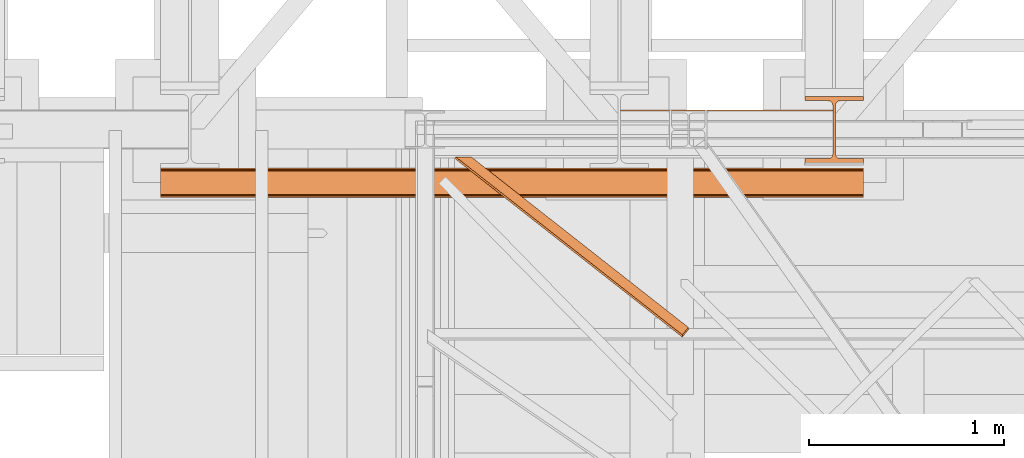
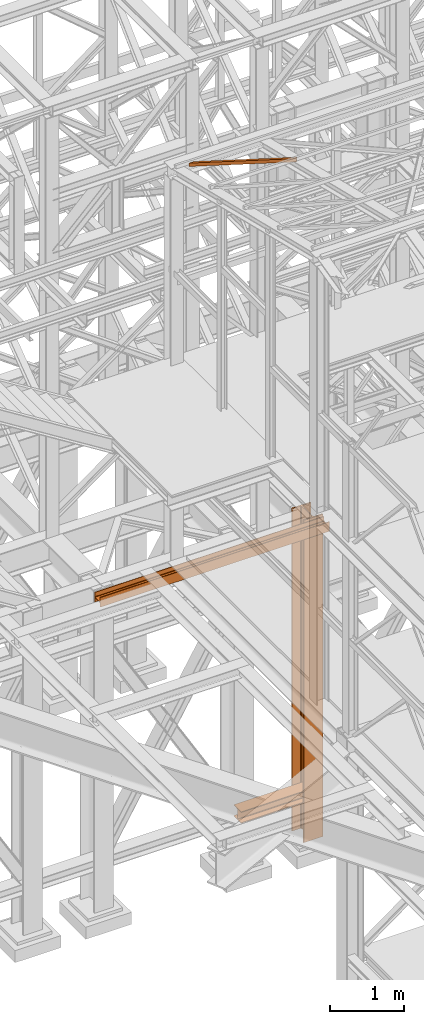
# One storey, part 38 of 208: 4 proxies.
"""IFC2X3 building model written with IfcOpenShell, lengths in millimetres."""

from ifc_helpers import new_model, entity, si_unit, converted_unit, frame, origin, origin_with_axes, place, context, subcontext, project, spatial, faceted_brep, material, element, save


model = new_model("IFC2X3")

# Units and contexts
model_context = context("Model", 3, precision=1e-05, world=origin())
plan_context = context("Plan", 3, precision=1e-05, world=origin())
body_context = subcontext(model_context, "Body", "Model", "MODEL_VIEW")
ifc_project = project(units=[si_unit("LENGTHUNIT", "METRE", prefix="MILLI"), converted_unit("PLANEANGLEUNIT", "DEGREE", entity("IfcPlaneAngleMeasure", 0.0174532925199433), si_unit("PLANEANGLEUNIT", "RADIAN"), dimensions=[0, 0, 0, 0, 0, 0, 0]), si_unit("AREAUNIT", "SQUARE_METRE"), si_unit("VOLUMEUNIT", "CUBIC_METRE")], contexts=[model_context, plan_context])

# Building, storey
building_placement = place(None, origin())
building = spatial("IfcBuilding", under=ifc_project, at=building_placement, CompositionType="COMPLEX")
storey_placement = place(building_placement, origin_with_axes())
storey = spatial("IfcBuildingStorey", under=building, at=storey_placement, Name="Geschoss", CompositionType="ELEMENT")

# Proxies
ifc_material = material(Name="35/80cm")
proxy_1_placement = place(storey_placement, frame((3143.254962568202, -17432.57439531565, -65.01000000000022), z_axis=(0.0, 0.0, 1.0), x_axis=(1.0, 0.0, 0.0)))
element("IfcBuildingElementProxy", 1, at=proxy_1_placement, inside=storey, material=ifc_material, context=body_context, shape_type="Brep", body=[
    faceted_brep([(300.0100119209292, 0.00999999999839929, 0.01000000000027512), (300.0100119209292, 21.51000631809075, 0.01000000000027512), (183.0100057816508, 21.51000631809075, 0.01000000000027512), (169.036290997863, 24.30682016372521, 0.01000000000027512), (158.8068282401564, 34.5362885093673, 0.01000000000027512), (156.0100060126188, 48.51000143050987, 0.01000000000027512), (156.0100060126188, 291.509994695185, 0.01000000000027512), (158.8068282401564, 305.4837150669082, 0.01000000000027512), (169.036290997863, 315.7131685113891, 0.01000000000027512), (183.0100057816508, 318.5099972581847, 0.01000000000027512), (300.0100119209292, 318.5099972581847, 0.01000000000027512), (300.0100119209292, 340.0100035762771, 0.01000000000027512), (0.01000000000021828, 340.0100035762771, 0.01000000000027512), (0.01000000000021828, 318.5099972581847, 0.01000000000027512), (117.0100061392786, 318.5099972581847, 0.01000000000027512), (130.9837209230664, 315.7131685113891, 0.01000000000027512), (141.213183680773, 305.4837150669082, 0.01000000000027512), (144.0100059083106, 291.509994695185, 0.01000000000027512), (144.0100059083106, 48.51000143050987, 0.01000000000027512), (141.213183680773, 34.5362885093673, 0.01000000000027512), (130.9837209230664, 24.30682016372521, 0.01000000000027512), (117.0100061392786, 21.51000631809075, 0.01000000000027512), (0.01000000000021828, 21.51000631809075, 0.01000000000027512), (0.01000000000021828, 0.00999999999839929, 0.01000000000027512), (300.0100119209292, 21.51000631809075, 5350.010005364416), (300.0100119209292, 0.00999999999839929, 5350.010005364416), (0.01000000000021828, 0.00999999999839929, 5350.010005364416), (0.01000000000021828, 21.51000631809075, 5350.010005364416), (117.0100061392786, 21.51000631809075, 5350.010005364416), (130.9837209230664, 24.30682016372521, 5350.010005364416), (141.213183680773, 34.5362885093673, 5350.010005364416), (144.0100059083106, 48.51000143050987, 5350.010005364416), (144.0100059083106, 291.509994695185, 5350.010005364416), (141.213183680773, 305.4837150669082, 5350.010005364416), (130.9837209230664, 315.7131685113891, 5350.010005364416), (117.0100061392786, 318.5099972581847, 5350.010005364416), (0.01000000000021828, 318.5099972581847, 5350.010005364416), (0.01000000000021828, 340.0100035762771, 5350.010005364416), (300.0100119209292, 340.0100035762771, 5350.010005364416), (300.0100119209292, 318.5099972581847, 5350.010005364416), (183.0100057816508, 318.5099972581847, 5350.010005364416), (169.036290997863, 315.7131685113891, 5350.010005364416), (158.8068282401564, 305.4837150669082, 5350.010005364416), (156.0100060126188, 291.509994695185, 5350.010005364416), (156.0100060126188, 48.51000143050987, 5350.010005364416), (158.8068282401564, 34.5362885093673, 5350.010005364416), (169.036290997863, 24.30682016372521, 5350.010005364416), (183.0100057816508, 21.51000631809075, 5350.010005364416), (300.0100119209292, 21.51000631809075, 0.01000000000027512), (300.0100119209292, 0.00999999999839929, 0.01000000000027512), (300.0100119209292, 0.00999999999839929, 5350.010005364416), (300.0100119209292, 21.51000631809075, 5350.010005364416), (183.0100057816508, 21.51000631809075, 0.01000000000027512), (300.0100119209292, 21.51000631809075, 0.01000000000027512), (300.0100119209292, 21.51000631809075, 5350.010005364416), (183.0100057816508, 21.51000631809075, 5350.010005364416), (169.036290997863, 24.30682016372521, 0.01000000000027512), (183.0100057816508, 21.51000631809075, 0.01000000000027512), (183.0100057816508, 21.51000631809075, 5350.010005364416), (169.036290997863, 24.30682016372521, 5350.010005364416), (158.8068282401564, 34.5362885093673, 0.01000000000027512), (169.036290997863, 24.30682016372521, 0.01000000000027512), (169.036290997863, 24.30682016372521, 5350.010005364416), (158.8068282401564, 34.5362885093673, 5350.010005364416), (156.0100060126188, 48.51000143050987, 0.01000000000027512), (158.8068282401564, 34.5362885093673, 0.01000000000027512), (158.8068282401564, 34.5362885093673, 5350.010005364416), (156.0100060126188, 48.51000143050987, 5350.010005364416), (156.0100060126188, 291.509994695185, 0.01000000000027512), (156.0100060126188, 48.51000143050987, 0.01000000000027512), (156.0100060126188, 48.51000143050987, 5350.010005364416), (156.0100060126188, 291.509994695185, 5350.010005364416), (158.8068282401564, 305.4837150669082, 0.01000000000027512), (156.0100060126188, 291.509994695185, 0.01000000000027512), (156.0100060126188, 291.509994695185, 5350.010005364416), (158.8068282401564, 305.4837150669082, 5350.010005364416), (169.036290997863, 315.7131685113891, 0.01000000000027512), (158.8068282401564, 305.4837150669082, 0.01000000000027512), (158.8068282401564, 305.4837150669082, 5350.010005364416), (169.036290997863, 315.7131685113891, 5350.010005364416), (183.0100057816508, 318.5099972581847, 0.01000000000027512), (169.036290997863, 315.7131685113891, 0.01000000000027512), (169.036290997863, 315.7131685113891, 5350.010005364416), (183.0100057816508, 318.5099972581847, 5350.010005364416), (300.0100119209292, 318.5099972581847, 0.01000000000027512), (183.0100057816508, 318.5099972581847, 0.01000000000027512), (183.0100057816508, 318.5099972581847, 5350.010005364416), (300.0100119209292, 318.5099972581847, 5350.010005364416), (300.0100119209292, 340.0100035762771, 0.01000000000027512), (300.0100119209292, 318.5099972581847, 0.01000000000027512), (300.0100119209292, 318.5099972581847, 5350.010005364416), (300.0100119209292, 340.0100035762771, 5350.010005364416), (0.01000000000021828, 340.0100035762771, 0.01000000000027512), (300.0100119209292, 340.0100035762771, 0.01000000000027512), (300.0100119209292, 340.0100035762771, 5350.010005364416), (0.01000000000021828, 340.0100035762771, 5350.010005364416), (0.01000000000021828, 318.5099972581847, 0.01000000000027512), (0.01000000000021828, 340.0100035762771, 0.01000000000027512), (0.01000000000021828, 340.0100035762771, 5350.010005364416), (0.01000000000021828, 318.5099972581847, 5350.010005364416), (117.0100061392786, 318.5099972581847, 0.01000000000027512), (0.01000000000021828, 318.5099972581847, 0.01000000000027512), (0.01000000000021828, 318.5099972581847, 5350.010005364416), (117.0100061392786, 318.5099972581847, 5350.010005364416), (130.9837209230664, 315.7131685113891, 0.01000000000027512), (117.0100061392786, 318.5099972581847, 0.01000000000027512), (117.0100061392786, 318.5099972581847, 5350.010005364416), (130.9837209230664, 315.7131685113891, 5350.010005364416), (141.213183680773, 305.4837150669082, 0.01000000000027512), (130.9837209230664, 315.7131685113891, 0.01000000000027512), (130.9837209230664, 315.7131685113891, 5350.010005364416), (141.213183680773, 305.4837150669082, 5350.010005364416), (144.0100059083106, 291.509994695185, 0.01000000000027512), (141.213183680773, 305.4837150669082, 0.01000000000027512), (141.213183680773, 305.4837150669082, 5350.010005364416), (144.0100059083106, 291.509994695185, 5350.010005364416), (144.0100059083106, 48.51000143050987, 0.01000000000027512), (144.0100059083106, 291.509994695185, 0.01000000000027512), (144.0100059083106, 291.509994695185, 5350.010005364416), (144.0100059083106, 48.51000143050987, 5350.010005364416), (141.213183680773, 34.5362885093673, 0.01000000000027512), (144.0100059083106, 48.51000143050987, 0.01000000000027512), (144.0100059083106, 48.51000143050987, 5350.010005364416), (141.213183680773, 34.5362885093673, 5350.010005364416), (130.9837209230664, 24.30682016372521, 0.01000000000027512), (141.213183680773, 34.5362885093673, 0.01000000000027512), (141.213183680773, 34.5362885093673, 5350.010005364416), (130.9837209230664, 24.30682016372521, 5350.010005364416), (117.0100061392786, 21.51000631809075, 0.01000000000027512), (130.9837209230664, 24.30682016372521, 0.01000000000027512), (130.9837209230664, 24.30682016372521, 5350.010005364416), (117.0100061392786, 21.51000631809075, 5350.010005364416), (0.01000000000021828, 21.51000631809075, 0.01000000000027512), (117.0100061392786, 21.51000631809075, 0.01000000000027512), (117.0100061392786, 21.51000631809075, 5350.010005364416), (0.01000000000021828, 21.51000631809075, 5350.010005364416), (0.01000000000021828, 0.00999999999839929, 0.01000000000027512), (0.01000000000021828, 21.51000631809075, 0.01000000000027512), (0.01000000000021828, 21.51000631809075, 5350.010005364416), (0.01000000000021828, 0.00999999999839929, 5350.010005364416), (300.0100119209292, 0.00999999999839929, 0.01000000000027512), (0.01000000000021828, 0.00999999999839929, 0.01000000000027512), (0.01000000000021828, 0.00999999999839929, 5350.010005364416), (300.0100119209292, 0.00999999999839929, 5350.010005364416)], [[[0, 1, 2, 3, 4, 5, 6, 7, 8, 9, 10, 11, 12, 13, 14, 15, 16, 17, 18, 19, 20, 21, 22, 23]], [[24, 25, 26, 27, 28, 29, 30, 31, 32, 33, 34, 35, 36, 37, 38, 39, 40, 41, 42, 43, 44, 45, 46, 47]], [[48, 49, 50, 51]], [[52, 53, 54, 55]], [[56, 57, 58, 59]], [[60, 61, 62, 63]], [[64, 65, 66, 67]], [[68, 69, 70, 71]], [[72, 73, 74, 75]], [[76, 77, 78, 79]], [[80, 81, 82, 83]], [[84, 85, 86, 87]], [[88, 89, 90, 91]], [[92, 93, 94, 95]], [[96, 97, 98, 99]], [[100, 101, 102, 103]], [[104, 105, 106, 107]], [[108, 109, 110, 111]], [[112, 113, 114, 115]], [[116, 117, 118, 119]], [[120, 121, 122, 123]], [[124, 125, 126, 127]], [[128, 129, 130, 131]], [[132, 133, 134, 135]], [[136, 137, 138, 139]], [[140, 141, 142, 143]]], orient=[[False], [False], [False], [False], [False], [False], [False], [False], [False], [False], [False], [False], [False], [False], [False], [False], [False], [False], [False], [False], [False], [False], [False], [False], [False], [False]]),
])
proxy_2_placement = place(storey_placement, frame((2200.00497459344, -17362.5323246858, 544.9900024165573), z_axis=(0.0, 0.0, 1.0), x_axis=(1.0, 0.0, 0.0)))
element("IfcBuildingElementProxy", 2, at=proxy_2_placement, inside=storey, context=body_context, shape_type="Brep", body=[
    faceted_brep([(1088.009999895692, 0.00999999999839929, 190.0100125169756), (1088.009999895692, 200.0100029802306, 190.0100125169756), (1088.009999895692, 200.0100029802306, 180.0100146031382), (1088.009999895692, 121.2600035762771, 180.0100071525576), (1088.009999895692, 111.9441915473326, 178.1454621052744), (1088.009999895692, 105.1245498640819, 171.3258190250399), (1088.009999895692, 103.2600015571697, 162.010007927418), (1088.009999895692, 103.2600015571697, 28.00999713897727), (1088.009999895692, 105.1245498640819, 18.69418604135535), (1088.009999895692, 111.9441915473326, 11.87454296112082), (1088.009999895692, 121.2600035762771, 10.00999791383765), (1088.009999895692, 200.0100029802306, 10.00999791383765), (1088.009999895692, 200.0100029802306, 0.01000000000021828), (1088.009999895692, 0.00999999999839929, 0.01000000000021828), (1088.009999895692, 0.00999999999839929, 10.00999791383765), (1088.009999895692, 78.75999940395195, 10.00999791383765), (1088.009999895692, 88.07581143289644, 11.87454296112082), (1088.009999895692, 94.89545311614711, 18.69418604135535), (1088.009999895692, 96.7600014230593, 28.00999713897727), (1088.009999895692, 96.7600014230593, 162.010007927418), (1088.009999895692, 94.89545311614711, 171.3258190250399), (1088.009999895692, 88.07581143289644, 178.1454621052744), (1088.009999895692, 78.75999940395195, 180.0100071525576), (1088.009999895692, 0.00999999999839929, 180.0100146031382), (1088.009999895692, 200.0100029802306, 190.0100125169756), (1088.009999895692, 0.00999999999839929, 190.0100125169756), (0.01000000000021828, 0.00999999999839929, 190.0100125169755), (0.01000000000021828, 200.0100029802306, 190.0100125169755), (1088.009999895692, 200.0100029802306, 180.0100146031382), (1088.009999895692, 200.0100029802306, 190.0100125169756), (0.01000000000021828, 200.0100029802306, 190.0100125169755), (0.01000000000021828, 200.0100029802306, 180.0100146031381), (1088.009999895692, 121.2600035762771, 180.0100071525576), (1088.009999895692, 200.0100029802306, 180.0100146031382), (0.01000000000021828, 200.0100029802306, 180.0100146031381), (0.01000000000021828, 121.2600035762771, 180.0100071525575), (1088.009999895692, 111.9441915473326, 178.1454621052744), (1088.009999895692, 121.2600035762771, 180.0100071525576), (0.01000000000021828, 121.2600035762771, 180.0100071525575), (0.01000000000021828, 111.9441915473326, 178.1454621052743), (1088.009999895692, 105.1245498640819, 171.3258190250399), (1088.009999895692, 111.9441915473326, 178.1454621052744), (0.01000000000021828, 111.9441915473326, 178.1454621052743), (0.01000000000021828, 105.1245498640819, 171.3258190250398), (1088.009999895692, 103.2600015571697, 162.010007927418), (1088.009999895692, 105.1245498640819, 171.3258190250399), (0.01000000000021828, 105.1245498640819, 171.3258190250398), (0.01000000000021828, 103.2600015571697, 162.0100079274179), (1088.009999895692, 103.2600015571697, 28.00999713897727), (1088.009999895692, 103.2600015571697, 162.010007927418), (0.01000000000021828, 103.2600015571697, 162.0100079274179), (0.01000000000021828, 103.2600015571697, 28.00999713897716), (1088.009999895692, 105.1245498640819, 18.69418604135535), (1088.009999895692, 103.2600015571697, 28.00999713897727), (0.01000000000021828, 103.2600015571697, 28.00999713897716), (0.01000000000021828, 105.1245498640819, 18.69418604135524), (1088.009999895692, 111.9441915473326, 11.87454296112082), (1088.009999895692, 105.1245498640819, 18.69418604135535), (0.01000000000021828, 105.1245498640819, 18.69418604135524), (0.01000000000021828, 111.9441915473326, 11.87454296112071), (1088.009999895692, 121.2600035762771, 10.00999791383765), (1088.009999895692, 111.9441915473326, 11.87454296112082), (0.01000000000021828, 111.9441915473326, 11.87454296112071), (0.01000000000021828, 121.2600035762771, 10.00999791383754), (1088.009999895692, 200.0100029802306, 10.00999791383765), (1088.009999895692, 121.2600035762771, 10.00999791383765), (0.01000000000021828, 121.2600035762771, 10.00999791383754), (0.01000000000021828, 200.0100029802306, 10.00999791383754), (1088.009999895692, 200.0100029802306, 0.01000000000021828), (1088.009999895692, 200.0100029802306, 10.00999791383765), (0.01000000000021828, 200.0100029802306, 10.00999791383754), (0.01000000000021828, 200.0100029802306, 0.01000000000010459), (1088.009999895692, 0.00999999999839929, 0.01000000000021828), (1088.009999895692, 200.0100029802306, 0.01000000000021828), (0.01000000000021828, 200.0100029802306, 0.01000000000010459), (0.01000000000021828, 0.00999999999839929, 0.01000000000010459), (1088.009999895692, 0.00999999999839929, 10.00999791383765), (1088.009999895692, 0.00999999999839929, 0.01000000000021828), (0.01000000000021828, 0.00999999999839929, 0.01000000000010459), (0.01000000000021828, 0.00999999999839929, 10.00999791383754), (1088.009999895692, 78.75999940395195, 10.00999791383765), (1088.009999895692, 0.00999999999839929, 10.00999791383765), (0.01000000000021828, 0.00999999999839929, 10.00999791383754), (0.01000000000021828, 78.75999940395195, 10.00999791383754), (1088.009999895692, 88.07581143289644, 11.87454296112082), (1088.009999895692, 78.75999940395195, 10.00999791383765), (0.01000000000021828, 78.75999940395195, 10.00999791383754), (0.01000000000021828, 88.07581143289644, 11.87454296112071), (1088.009999895692, 94.89545311614711, 18.69418604135535), (1088.009999895692, 88.07581143289644, 11.87454296112082), (0.01000000000021828, 88.07581143289644, 11.87454296112071), (0.01000000000021828, 94.89545311614711, 18.69418604135524), (1088.009999895692, 96.7600014230593, 28.00999713897727), (1088.009999895692, 94.89545311614711, 18.69418604135535), (0.01000000000021828, 94.89545311614711, 18.69418604135524), (0.01000000000021828, 96.7600014230593, 28.00999713897716), (1088.009999895692, 96.7600014230593, 162.010007927418), (1088.009999895692, 96.7600014230593, 28.00999713897727), (0.01000000000021828, 96.7600014230593, 28.00999713897716), (0.01000000000021828, 96.7600014230593, 162.0100079274179), (1088.009999895692, 94.89545311614711, 171.3258190250399), (1088.009999895692, 96.7600014230593, 162.010007927418), (0.01000000000021828, 96.7600014230593, 162.0100079274179), (0.01000000000021828, 94.89545311614711, 171.3258190250398), (1088.009999895692, 88.07581143289644, 178.1454621052744), (1088.009999895692, 94.89545311614711, 171.3258190250399), (0.01000000000021828, 94.89545311614711, 171.3258190250398), (0.01000000000021828, 88.07581143289644, 178.1454621052743), (1088.009999895692, 78.75999940395195, 180.0100071525576), (1088.009999895692, 88.07581143289644, 178.1454621052744), (0.01000000000021828, 88.07581143289644, 178.1454621052743), (0.01000000000021828, 78.75999940395195, 180.0100071525575), (1088.009999895692, 0.00999999999839929, 180.0100146031382), (1088.009999895692, 78.75999940395195, 180.0100071525576), (0.01000000000021828, 78.75999940395195, 180.0100071525575), (0.01000000000021828, 0.00999999999839929, 180.0100146031381), (1088.009999895692, 0.00999999999839929, 190.0100125169756), (1088.009999895692, 0.00999999999839929, 180.0100146031382), (0.01000000000021828, 0.00999999999839929, 180.0100146031381), (0.01000000000021828, 0.00999999999839929, 190.0100125169755), (0.01000000000021828, 0.00999999999839929, 190.0100125169755), (0.01000000000021828, 0.00999999999839929, 180.0100146031381), (0.01000000000021828, 78.75999940395195, 180.0100071525575), (0.01000000000021828, 88.07581143289644, 178.1454621052743), (0.01000000000021828, 94.89545311614711, 171.3258190250398), (0.01000000000021828, 96.7600014230593, 162.0100079274179), (0.01000000000021828, 96.7600014230593, 28.00999713897716), (0.01000000000021828, 94.89545311614711, 18.69418604135524), (0.01000000000021828, 88.07581143289644, 11.87454296112071), (0.01000000000021828, 78.75999940395195, 10.00999791383754), (0.01000000000021828, 0.00999999999839929, 10.00999791383754), (0.01000000000021828, 0.00999999999839929, 0.01000000000010459), (0.01000000000021828, 200.0100029802306, 0.01000000000010459), (0.01000000000021828, 200.0100029802306, 10.00999791383754), (0.01000000000021828, 121.2600035762771, 10.00999791383754), (0.01000000000021828, 111.9441915473326, 11.87454296112071), (0.01000000000021828, 105.1245498640819, 18.69418604135524), (0.01000000000021828, 103.2600015571697, 28.00999713897716), (0.01000000000021828, 103.2600015571697, 162.0100079274179), (0.01000000000021828, 105.1245498640819, 171.3258190250398), (0.01000000000021828, 111.9441915473326, 178.1454621052743), (0.01000000000021828, 121.2600035762771, 180.0100071525575), (0.01000000000021828, 200.0100029802306, 180.0100146031381), (0.01000000000021828, 200.0100029802306, 190.0100125169755)], [[[0, 1, 2, 3, 4, 5, 6, 7, 8, 9, 10, 11, 12, 13, 14, 15, 16, 17, 18, 19, 20, 21, 22, 23]], [[24, 25, 26, 27]], [[28, 29, 30, 31]], [[32, 33, 34, 35]], [[36, 37, 38, 39]], [[40, 41, 42, 43]], [[44, 45, 46, 47]], [[48, 49, 50, 51]], [[52, 53, 54, 55]], [[56, 57, 58, 59]], [[60, 61, 62, 63]], [[64, 65, 66, 67]], [[68, 69, 70, 71]], [[72, 73, 74, 75]], [[76, 77, 78, 79]], [[80, 81, 82, 83]], [[84, 85, 86, 87]], [[88, 89, 90, 91]], [[92, 93, 94, 95]], [[96, 97, 98, 99]], [[100, 101, 102, 103]], [[104, 105, 106, 107]], [[108, 109, 110, 111]], [[112, 113, 114, 115]], [[116, 117, 118, 119]], [[120, 121, 122, 123, 124, 125, 126, 127, 128, 129, 130, 131, 132, 133, 134, 135, 136, 137, 138, 139, 140, 141, 142, 143]]], orient=[[False], [False], [False], [False], [False], [False], [False], [False], [False], [False], [False], [False], [False], [False], [False], [False], [False], [False], [False], [False], [False], [False], [False], [False], [False], [False]]),
])
proxy_3_placement = place(storey_placement, frame((-156.7450314713294, -17610.57440532924, 5107.409888653881), z_axis=(0.0, 0.0, 1.0), x_axis=(1.0, 0.0, 0.0)))
element("IfcBuildingElementProxy", 3, at=proxy_3_placement, inside=storey, context=body_context, shape_type="Brep", body=[
    faceted_brep([(3600.010005960461, 0.01000000000567525, 0.01000000000021828), (3600.010005960461, 0.01000000000567525, 160.0100113248827), (3600.010005960461, 9.010003337865783, 160.0100113248827), (3600.010005960461, 9.010003337865783, 98.01000675022624), (3600.010005960461, 10.56379211903186, 90.24683052510045), (3600.010005960461, 16.24682677746387, 84.56379586666844), (3600.010005960461, 24.01000020862193, 83.0100056885185), (3600.010005960461, 128.0100060796794, 83.0100056885185), (3600.010005960461, 135.7731832361278, 84.56379586666844), (3600.010005960461, 141.4562178945598, 90.24683052510045), (3600.010005960461, 143.0100066757259, 98.01000675022624), (3600.010005960461, 143.0100066757259, 160.0100113248827), (3600.010005960461, 152.010010013586, 160.0100113248827), (3600.010005960461, 152.010010013586, 0.01000000000021828), (3600.010005960461, 143.0100066757259, 0.01000000000021828), (3600.010005960461, 143.0100066757259, 62.01000457465671), (3600.010005960461, 141.4562178945598, 69.7731807997825), (3600.010005960461, 135.7731832361278, 75.4562154582145), (3600.010005960461, 128.0100060796794, 77.01000563636444), (3600.010005960461, 24.01000020862193, 77.01000563636444), (3600.010005960461, 16.24682677746387, 75.4562154582145), (3600.010005960461, 10.56379211903186, 69.7731807997825), (3600.010005960461, 9.010003337865783, 62.01000457465671), (3600.010005960461, 9.010003337865783, 0.01000000000021828), (3600.010005960461, 0.01000000000567525, 160.0100113248827), (3600.010005960461, 0.01000000000567525, 0.01000000000021828), (0.009999999999990905, 0.01000000000203727, 0.01000000000385626), (0.009999999999990905, 0.01000000000203727, 160.0100113248827), (3600.010005960461, 9.010003337865783, 160.0100113248827), (3600.010005960461, 0.01000000000567525, 160.0100113248827), (0.009999999999990905, 0.01000000000203727, 160.0100113248827), (0.009999999999990905, 9.010003337862145, 160.0100113248827), (3600.010005960461, 9.010003337865783, 98.01000675022624), (3600.010005960461, 9.010003337865783, 160.0100113248827), (0.009999999999990905, 9.010003337862145, 160.0100113248827), (0.009999999999990905, 9.010003337862145, 98.01000675022624), (3600.010005960461, 10.56379211903186, 90.24683052510045), (3600.010005960461, 9.010003337865783, 98.01000675022624), (0.009999999999990905, 9.010003337862145, 98.01000675022624), (0.009999999999990905, 10.56379211902822, 90.24683052510409), (3600.010005960461, 16.24682677746387, 84.56379586666844), (3600.010005960461, 10.56379211903186, 90.24683052510045), (0.009999999999990905, 10.56379211902822, 90.24683052510409), (0.009999999999990905, 16.24682677746023, 84.56379586667208), (3600.010005960461, 24.01000020862193, 83.0100056885185), (3600.010005960461, 16.24682677746387, 84.56379586666844), (0.009999999999990905, 16.24682677746023, 84.56379586667208), (0.009999999999990905, 24.01000020861829, 83.01000568852214), (3600.010005960461, 128.0100060796794, 83.0100056885185), (3600.010005960461, 24.01000020862193, 83.0100056885185), (0.009999999999990905, 24.01000020861829, 83.01000568852214), (0.009999999999990905, 128.0100060796758, 83.01000568852214), (3600.010005960461, 135.7731832361278, 84.56379586666844), (3600.010005960461, 128.0100060796794, 83.0100056885185), (0.009999999999990905, 128.0100060796758, 83.01000568852214), (0.009999999999990905, 135.7731832361242, 84.56379586667208), (3600.010005960461, 141.4562178945598, 90.24683052510045), (3600.010005960461, 135.7731832361278, 84.56379586666844), (0.009999999999990905, 135.7731832361242, 84.56379586667208), (0.009999999999990905, 141.4562178945562, 90.24683052510409), (3600.010005960461, 143.0100066757259, 98.01000675022624), (3600.010005960461, 141.4562178945598, 90.24683052510045), (0.009999999999990905, 141.4562178945562, 90.24683052510409), (0.009999999999990905, 143.0100066757223, 98.01000675022988), (3600.010005960461, 143.0100066757259, 160.0100113248827), (3600.010005960461, 143.0100066757259, 98.01000675022624), (0.009999999999990905, 143.0100066757223, 98.01000675022988), (0.009999999999990905, 143.0100066757223, 160.0100113248827), (3600.010005960461, 152.010010013586, 160.0100113248827), (3600.010005960461, 143.0100066757259, 160.0100113248827), (0.009999999999990905, 143.0100066757223, 160.0100113248827), (0.009999999999990905, 152.0100100135824, 160.0100113248827), (3600.010005960461, 152.010010013586, 0.01000000000021828), (3600.010005960461, 152.010010013586, 160.0100113248827), (0.009999999999990905, 152.0100100135824, 160.0100113248827), (0.009999999999990905, 152.010010013586, 0.01000000000021828), (3600.010005960461, 143.0100066757259, 0.01000000000021828), (3600.010005960461, 152.010010013586, 0.01000000000021828), (0.009999999999990905, 152.010010013586, 0.01000000000021828), (0.009999999999990905, 143.0100066757223, 0.01000000000021828), (3600.010005960461, 143.0100066757259, 62.01000457465671), (3600.010005960461, 143.0100066757259, 0.01000000000021828), (0.009999999999990905, 143.0100066757223, 0.01000000000021828), (0.009999999999990905, 143.0100066757223, 62.01000457466034), (3600.010005960461, 141.4562178945598, 69.7731807997825), (3600.010005960461, 143.0100066757259, 62.01000457465671), (0.009999999999990905, 143.0100066757223, 62.01000457466034), (0.009999999999990905, 141.4562178945562, 69.77318079978613), (3600.010005960461, 135.7731832361278, 75.4562154582145), (3600.010005960461, 141.4562178945598, 69.7731807997825), (0.009999999999990905, 141.4562178945562, 69.77318079978613), (0.009999999999990905, 135.7731832361278, 75.45621545821814), (3600.010005960461, 128.0100060796794, 77.01000563636444), (3600.010005960461, 135.7731832361278, 75.4562154582145), (0.009999999999990905, 135.7731832361278, 75.45621545821814), (0.009999999999990905, 128.0100060796794, 77.01000563636808), (3600.010005960461, 24.01000020862193, 77.01000563636444), (3600.010005960461, 128.0100060796794, 77.01000563636444), (0.009999999999990905, 128.0100060796794, 77.01000563636808), (0.009999999999990905, 24.01000020861829, 77.01000563636808), (3600.010005960461, 16.24682677746387, 75.4562154582145), (3600.010005960461, 24.01000020862193, 77.01000563636444), (0.009999999999990905, 24.01000020861829, 77.01000563636808), (0.009999999999990905, 16.24682677746023, 75.45621545821814), (3600.010005960461, 10.56379211903186, 69.7731807997825), (3600.010005960461, 16.24682677746387, 75.4562154582145), (0.009999999999990905, 16.24682677746023, 75.45621545821814), (0.009999999999990905, 10.56379211902822, 69.77318079978613), (3600.010005960461, 9.010003337865783, 62.01000457465671), (3600.010005960461, 10.56379211903186, 69.7731807997825), (0.009999999999990905, 10.56379211902822, 69.77318079978613), (0.009999999999990905, 9.010003337862145, 62.01000457466034), (3600.010005960461, 9.010003337865783, 0.01000000000021828), (3600.010005960461, 9.010003337865783, 62.01000457465671), (0.009999999999990905, 9.010003337862145, 62.01000457466034), (0.009999999999990905, 9.010003337862145, 0.01000000000021828), (3600.010005960461, 0.01000000000567525, 0.01000000000021828), (3600.010005960461, 9.010003337865783, 0.01000000000021828), (0.009999999999990905, 9.010003337862145, 0.01000000000021828), (0.009999999999990905, 0.01000000000203727, 0.01000000000385626), (0.009999999999990905, 0.01000000000203727, 0.01000000000385626), (0.009999999999990905, 9.010003337862145, 0.01000000000021828), (0.009999999999990905, 9.010003337862145, 62.01000457466034), (0.009999999999990905, 10.56379211902822, 69.77318079978613), (0.009999999999990905, 16.24682677746023, 75.45621545821814), (0.009999999999990905, 24.01000020861829, 77.01000563636808), (0.009999999999990905, 128.0100060796794, 77.01000563636808), (0.009999999999990905, 135.7731832361278, 75.45621545821814), (0.009999999999990905, 141.4562178945562, 69.77318079978613), (0.009999999999990905, 143.0100066757223, 62.01000457466034), (0.009999999999990905, 143.0100066757223, 0.01000000000021828), (0.009999999999990905, 152.010010013586, 0.01000000000021828), (0.009999999999990905, 152.0100100135824, 160.0100113248827), (0.009999999999990905, 143.0100066757223, 160.0100113248827), (0.009999999999990905, 143.0100066757223, 98.01000675022988), (0.009999999999990905, 141.4562178945562, 90.24683052510409), (0.009999999999990905, 135.7731832361242, 84.56379586667208), (0.009999999999990905, 128.0100060796758, 83.01000568852214), (0.009999999999990905, 24.01000020861829, 83.01000568852214), (0.009999999999990905, 16.24682677746023, 84.56379586667208), (0.009999999999990905, 10.56379211902822, 90.24683052510409), (0.009999999999990905, 9.010003337862145, 98.01000675022624), (0.009999999999990905, 9.010003337862145, 160.0100113248827), (0.009999999999990905, 0.01000000000203727, 160.0100113248827)], [[[0, 1, 2, 3, 4, 5, 6, 7, 8, 9, 10, 11, 12, 13, 14, 15, 16, 17, 18, 19, 20, 21, 22, 23]], [[24, 25, 26, 27]], [[28, 29, 30, 31]], [[32, 33, 34, 35]], [[36, 37, 38, 39]], [[40, 41, 42, 43]], [[44, 45, 46, 47]], [[48, 49, 50, 51]], [[52, 53, 54, 55]], [[56, 57, 58, 59]], [[60, 61, 62, 63]], [[64, 65, 66, 67]], [[68, 69, 70, 71]], [[72, 73, 74, 75]], [[76, 77, 78, 79]], [[80, 81, 82, 83]], [[84, 85, 86, 87]], [[88, 89, 90, 91]], [[92, 93, 94, 95]], [[96, 97, 98, 99]], [[100, 101, 102, 103]], [[104, 105, 106, 107]], [[108, 109, 110, 111]], [[112, 113, 114, 115]], [[116, 117, 118, 119]], [[120, 121, 122, 123, 124, 125, 126, 127, 128, 129, 130, 131, 132, 133, 134, 135, 136, 137, 138, 139, 140, 141, 142, 143]]], orient=[[False], [False], [False], [False], [False], [False], [False], [False], [False], [False], [False], [False], [False], [False], [False], [False], [False], [False], [False], [False], [False], [False], [False], [False], [False], [False]]),
])
proxy_4_placement = place(storey_placement, frame((1354.833466651513, -18325.01341388675, 11773.47119774096), z_axis=(0.0, 0.0, 1.0), x_axis=(1.0, 0.0, 0.0)))
element("IfcBuildingElementProxy", 4, at=proxy_4_placement, inside=storey, context=body_context, shape_type="Brep", body=[
    faceted_brep([(1160.705621299064, 0.00999999999839929, 221.2188035365398), (1160.705621299064, 11.80406569683692, 269.8078971104969), (1192.128805925273, 49.59855381965826, 260.6340137734806), (1192.128805925273, 37.80448812281975, 212.0449201995252), (0.009999999999990905, 923.1382511001539, 48.59909357395372), (1160.705621299064, 11.80406569683692, 269.8078971104969), (1160.705621299064, 0.00999999999839929, 221.2188035365398), (0.01000000000067303, 911.3441854033154, 0.00999999999839929), (0.01000000000067303, 911.3441854033154, 0.00999999999839929), (1160.705621299064, 0.00999999999839929, 221.2188035365398), (1192.128805925273, 37.80448812281975, 212.0449201995252), (79.5690908349552, 911.3441854033154, 0.00999999999839929), (79.5690908349552, 911.3441854033154, 0.00999999999839929), (1192.128805925273, 37.80448812281975, 212.0449201995252), (1192.128805925273, 49.59855381965826, 260.6340137734806), (79.5690908349527, 923.1382511001539, 48.59909357395554), (79.5690908349527, 923.1382511001539, 48.59909357395554), (1192.128805925273, 49.59855381965826, 260.6340137734806), (1160.705621299064, 11.80406569683692, 269.8078971104969), (0.009999999999990905, 923.1382511001539, 48.59909357395372), (0.009999999999990905, 923.1382511001539, 48.59909357395372), (0.01000000000067303, 911.3441854033154, 0.00999999999839929), (79.5690908349552, 911.3441854033154, 0.00999999999839929), (79.5690908349527, 923.1382511001539, 48.59909357395554)], [[[0, 1, 2, 3]], [[4, 5, 6, 7]], [[8, 9, 10, 11]], [[12, 13, 14, 15]], [[16, 17, 18, 19]], [[20, 21, 22, 23]]], orient=[[False], [False], [False], [False], [False], [False]]),
])

save(model, "model.ifc")
